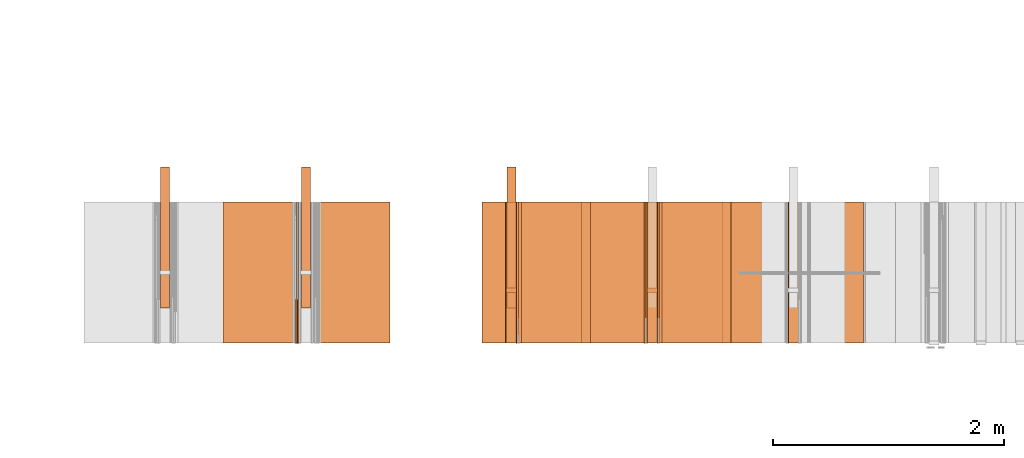
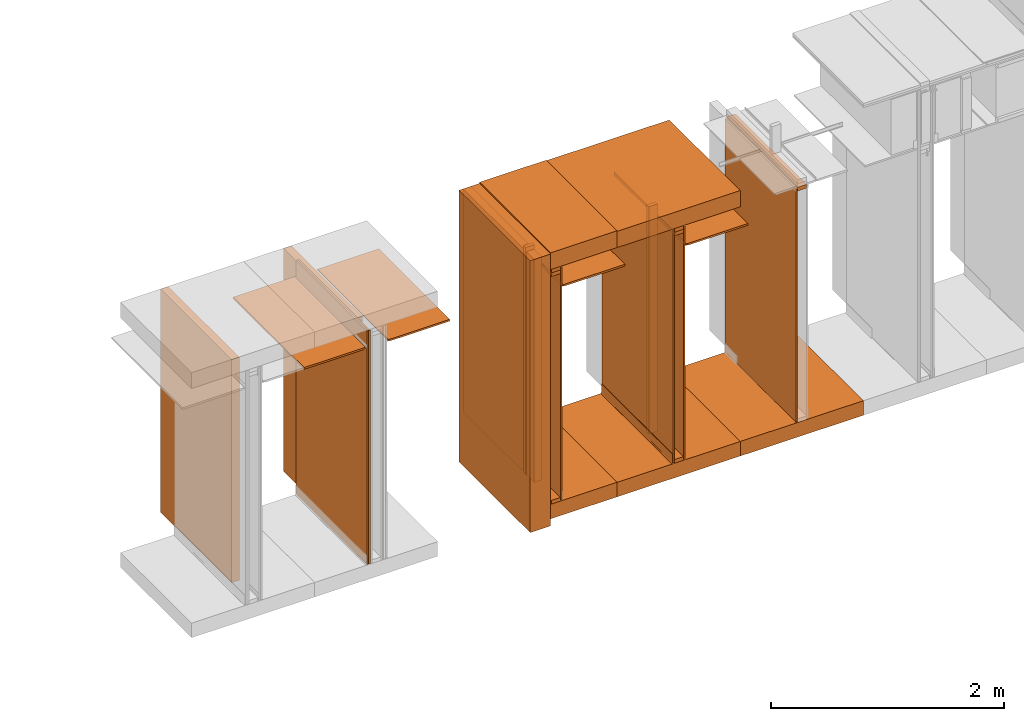
# One storey, part 8 of 38: 31 proxies.
"""IFC4 building model written with IfcOpenShell, lengths in feet."""

from ifc_helpers import new_model, entity, si_unit, converted_unit, frame, origin_with_axes, origin_2d_with_axis, place, context, subcontext, project, spatial, polyline, line, indexed_curve, outline, extrude, material, constituent, constituent_set, element, save


model = new_model("IFC4")

# Units and contexts
model_context_1 = context("Model", 3, precision=1e-05, world=origin_with_axes())
plan_context = context("Plan", 2, precision=1e-05, world=origin_2d_with_axis())
model_context_2 = context("Model", 3, precision=1e-05, world=origin_with_axes())
context_of_model_1 = context(None, 3, precision=1e-05, world=origin_with_axes())
context_of_model_2 = context(None, 3, precision=1e-05, world=origin_with_axes())
body_context = subcontext(model_context_2, "Body", "Model", "MODEL_VIEW")
ifc_project = project(units=[converted_unit("PLANEANGLEUNIT", "degree", entity("IfcReal", 0.0174532925199433), si_unit("PLANEANGLEUNIT", "RADIAN"), dimensions=[0, 0, 0, 0, 0, 0, 0]), converted_unit("AREAUNIT", "square foot", entity("IfcReal", 0.09290304), si_unit("AREAUNIT", "SQUARE_METRE"), dimensions=[2, 0, 0, 0, 0, 0, 0]), converted_unit("LENGTHUNIT", "foot", entity("IfcReal", 0.3048), si_unit("LENGTHUNIT", "METRE"), dimensions=[1, 0, 0, 0, 0, 0, 0]), converted_unit("VOLUMEUNIT", "cubic foot", entity("IfcReal", 0.0283168467116885), si_unit("VOLUMEUNIT", "CUBIC_METRE"), dimensions=[3, 0, 0, 0, 0, 0, 0])], contexts=[model_context_1, plan_context, context_of_model_1, context_of_model_2])

# Site, building, storey
site_placement = place(None, origin_with_axes())
site = spatial("IfcSite", under=ifc_project, at=site_placement)
building_placement = place(site_placement, origin_with_axes())
building = spatial("IfcBuilding", under=site, at=building_placement, Name="Building")
storey_placement = place(building_placement, origin_with_axes())
storey = spatial("IfcBuildingStorey", under=building, at=storey_placement, Name="Storey")

# Proxies
proxy_1_placement = place(storey_placement, frame((1379.04530122211, 5.99999987860051, 7.9530516634463), z_axis=(4.37113882867379e-08, -0.999999999999999, -8.51092183247426e-15), x_axis=(1.94707183709394e-07, 0.0, 0.999999999999981)))
element("IfcBuildingElementProxy", 1, at=proxy_1_placement, inside=storey, Name="Generic Models 48:Generic Models 1", PredefinedType="COMPLEX", context=body_context, shape_type="SweptSolid", body=[
    extrude(outline(polyline([(-0.145833333098669, -0.0625000007724355), (0.145833333098669, -0.0625000007724355), (0.145833333098669, 0.0625000007724355), (-0.145833333098669, 0.062500006883476), (-0.145833333098669, -0.0625000007724355)])), frame((0.0625000313276381, -0.145833320876588, -1.73846880315148e-08), z_axis=(-3.2778077805164e-14, 1.19209289550781e-07, -1.0), x_axis=(-1.94707197920252e-07, 1.0, 1.19209289550781e-07)), (5.72196491577248e-11, 5.40068767485025e-10, -1.0), 4.00000000752362),
])
proxy_2_placement = place(storey_placement, frame((1361.22916314233, 2.99999993930026, 0.125000001544871), z_axis=(0.0, 0.0, 1.0), x_axis=(-1.62920684942944e-07, 0.999999999999987, 0.0)))
element("IfcBuildingElementProxy", 2, at=proxy_2_placement, inside=storey, Name="Generic Models 498:Generic Models 1", PredefinedType="COMPLEX", context=body_context, shape_type="SweptSolid", body=[
    extrude(outline(polyline([(-2.00000002471794, -0.125000001544871), (2.00000002471794, -0.125000001544871), (2.00000002471794, 0.125000001544871), (-2.00000002471794, 0.125000001544871), (-2.00000002471794, -0.125000001544871)])), frame((2.00000002471794, -0.125000001544871, 0.0), z_axis=(0.0, 0.0, -1.0), x_axis=(-1.0, 0.0, 0.0)), (0.0, 0.0, -0.999999940395355), 7.66478654778766),
])
ifc_material_1 = material(Category="sand")
proxy_3_placement = place(storey_placement, frame((1378.99323711245, 5.99999987860051, 0.0208333330815585), z_axis=(4.37113882867379e-08, -0.999999999999999, -8.51092183247426e-15), x_axis=(1.94707183709394e-07, 0.0, 0.999999999999981)))
element("IfcBuildingElementProxy", 3, at=proxy_3_placement, inside=storey, material=ifc_material_1, Name="Generic Models 550:Generic Models 1", PredefinedType="COMPLEX", context=body_context, shape_type="SweptSolid", body=[
    extrude(outline(polyline([(-4.00429713757332, -0.0260416674977682), (4.00429713757332, -0.0260416674977682), (4.00429713757332, 0.0260416674977682), (-4.00429713757332, 0.0260416674977682), (-4.00429713757332, -0.0260416674977682)])), frame((4.00429713757332, -0.0260408883401024, -3.10444292028814e-09), z_axis=(-3.17388734109685e-14, 1.19209289550781e-07, -1.0), x_axis=(1.0, 1.94707183709397e-07, -8.51092267950722e-15)), (-1.26761878771475e-09, 8.29316199046914e-11, -1.0), 4.00000000752362),
])
ifc_material_2 = material(Name="STRUCTURAL FLOOR", Category="concrete")
proxy_4_placement = place(storey_placement, frame((1377.1823072058, 5.99999987860051, -0.500000006179484), z_axis=(4.37113882867379e-08, -0.999999999999999, -8.51092183247426e-15), x_axis=(1.94707183709394e-07, 0.0, 0.999999999999981)))
element("IfcBuildingElementProxy", 4, at=proxy_4_placement, inside=storey, material=ifc_material_2, Name="Generic Models 561:Generic Models 1", PredefinedType="COMPLEX", context=body_context, shape_type="SweptSolid", body=[
    extrude(outline(polyline([(-0.250000003089742, -2.00000002471794), (0.250000003089742, -2.00000002471794), (0.250000003089742, 2.00000002471794), (-0.250000003089742, 2.00000002471794), (-0.250000003089742, -2.00000002471794)])), frame((0.250000394196335, -2.00000002471794, -6.29525198374314e-07), z_axis=(0.0, 1.19209289550781e-07, -1.0), x_axis=(1.0, 1.94707183709397e-07, 0.0)), (4.23038687413779e-10, -9.26340160134487e-09, -1.0), 4.00000000752362),
])
ifc_constituent_set_1 = constituent_set(Name="concrete")
proxy_5_placement = place(storey_placement, frame((1373.18228173444, 5.99999987860051, -0.500000006179484), z_axis=(7.54979012640431e-08, -0.999999999999997, 5.69993288272772e-15), x_axis=(7.54979012640431e-08, 0.0, -0.999999999999997)))
element("IfcBuildingElementProxy", 5, at=proxy_5_placement, inside=storey, material=ifc_constituent_set_1, Name="Generic Models 11:Generic Models 1", PredefinedType="COMPLEX", context=body_context, shape_type="SweptSolid", body=[
    extrude(outline(polyline([(-0.249999905313094, -2.00000002471794), (0.250000174198876, -2.00000002471794), (0.249999880868932, 2.00000002471794), (-0.250000198643039, 2.00000002471794), (-0.249999905313094, -2.00000002471794)])), frame((-0.249999831980608, 2.00000002471794, -5.65952137880985e-07), z_axis=(0.0, -8.74227978897579e-08, -1.0), x_axis=(-1.0, 0.0, 0.0)), (0.0, 1.03538582152396e-08, -1.0), 4.00000000752362),
])
ifc_material_3 = material(Name="CEILING TRACK AS SCHEDULED", Category="poche")
proxy_6_placement = place(storey_placement, frame((1375.38539455944, 5.99999987860051, 7.35498241239332), z_axis=(7.54979012640431e-08, -0.999999999999997, 5.69993288272772e-15), x_axis=(7.54979012640431e-08, 0.0, -0.999999999999997)))
element("IfcBuildingElementProxy", 6, at=proxy_6_placement, inside=storey, material=ifc_material_3, Name="Generic Models 14:Generic Models 1", PredefinedType="COMPLEX", context=body_context, shape_type="SweptSolid", body=[
    extrude(outline(polyline([(-0.043402779162947, -0.029513890441908), (0.0815972223819241, -0.029513890441908), (0.0815972284929646, -0.0243055575534584), (-0.0381944432189771, -0.0243055575534584), (-0.0381944462744974, 0.0538194388288056), (-0.043402779162947, 0.0538194510508866), (-0.043402779162947, -0.029513890441908)])), frame((-0.0434019908387204, 0.0295138812753472, -3.93686786291257e-07), z_axis=(4.20818639808827e-14, -8.74224923563816e-08, -1.0), x_axis=(-1.0, 7.65208625352898e-08, 0.0)), (-1.99266270151099e-10, 2.64895128054832e-09, -1.0), 4.00000000752362),
])
proxy_7_placement = place(storey_placement, frame((1375.04167131239, 5.99999987860051, 7.81249968711472), z_axis=(7.54979012640431e-08, -0.999999999999997, 5.69993288272772e-15), x_axis=(7.54979012640431e-08, 0.0, -0.999999999999997)))
element("IfcBuildingElementProxy", 7, at=proxy_7_placement, inside=storey, Name="Generic Models 155:Generic Models 1", PredefinedType="COMPLEX", context=body_context, shape_type="SweptSolid", body=[
    extrude(outline(polyline([(-0.062500006883476, -0.145833333098669), (0.0625000007724355, -0.145833333098669), (0.062500006883476, 0.145833308654507), (-0.0625000007724355, 0.14583334532075), (-0.062500006883476, -0.145833333098669)])), frame((-0.0624991085605202, 0.145833320876588, -4.03855753155507e-07), z_axis=(0.0, -8.74228121006126e-08, -1.0), x_axis=(-1.0, 9.77766632104249e-08, 0.0)), (5.0926202144197e-10, -3.39597883147746e-09, -1.0), 4.00000000752362),
])
ifc_material_4 = material()
ifc_constituent = constituent(ifc_material_4)
ifc_constituent_set_2 = constituent_set(constituents=[ifc_constituent], Name="wood")
proxy_8_placement = place(storey_placement, frame((1375.04167131239, 5.99999987860051, -4.92006757396041e-14), z_axis=(7.54979012640431e-08, -0.999999999999997, 5.69993288272772e-15), x_axis=(7.54979012640431e-08, 0.0, -0.999999999999997)))
element("IfcBuildingElementProxy", 8, at=proxy_8_placement, inside=storey, material=ifc_constituent_set_2, Name="Generic Models 1:Generic Models 1", PredefinedType="COMPLEX", context=body_context, shape_type="SweptSolid", body=[
    extrude(outline(polyline([(-0.0624999641061924, -0.145833320876588), (0.0625000374386786, -0.145833320876588), (0.0624999579951519, 0.145833357542831), (-0.0625000435497191, 0.145833320876588), (-0.0624999641061924, -0.145833320876588)])), frame((-0.0624999885503545, 0.145833333098669, -4.03855753155507e-07), z_axis=(8.19452029832395e-15, -8.742281920604e-08, -1.0), x_axis=(1.0, 1.9555329799914e-07, 0.0)), (-5.09236153245496e-10, -1.18727372377947e-09, -1.0), 4.00000000752362),
])
proxy_9_placement = place(storey_placement, frame((1370.35419934691, 5.99999987860051, -0.741135700559366), z_axis=(7.54979012640431e-08, -0.999999999999997, 5.69993288272772e-15), x_axis=(7.54979012640431e-08, 0.0, -0.999999999999997)))
element("IfcBuildingElementProxy", 9, at=proxy_9_placement, inside=storey, Name="Generic Models 26:Generic Models 1", PredefinedType="COMPLEX", context=body_context, shape_type="SweptSolid", body=[
    extrude(outline(polyline([(-0.333333329304935, -4.66965471352805), (0.33333337819326, -4.66965471352805), (0.333333304860773, 4.66965471352805), (-0.333333329304935, 4.66965471352805), (-0.333333329304935, -4.66965471352805)])), frame((-4.66965471352805, 0.333333695967366, -4.20247517158809e-07), z_axis=(-1.15161688948276e-15, -8.74227765734759e-08, -1.0), x_axis=(-6.80508804862257e-08, -1.0, 8.74227623626211e-08)), (1.8681878266591e-09, 5.67091396064257e-09, -1.0), 4.00000000752362),
])
proxy_10_placement = place(storey_placement, frame((1375.33333044978, 5.99999987860051, 0.0208333330815585), z_axis=(7.54979012640431e-08, -0.999999999999997, 5.69993288272772e-15), x_axis=(7.54979012640431e-08, 0.0, -0.999999999999997)))
element("IfcBuildingElementProxy", 10, at=proxy_10_placement, inside=storey, material=ifc_material_1, Name="Generic Models 2:Generic Models 1", PredefinedType="COMPLEX", context=body_context, shape_type="SweptSolid", body=[
    extrude(outline(polyline([(-4.01041717354081, -0.0260416644422479), (4.01041717354081, -0.0260416644422479), (4.01041717354081, 0.0260416705532884), (-4.01041717354081, 0.0260416705532884), (-4.01041717354081, -0.0260416644422479)])), frame((-4.01041717354081, 0.026041973049794, -3.9338322042823e-07), z_axis=(-7.82204010086772e-16, -8.74215970725345e-08, -1.0), x_axis=(1.0, -7.54276925363229e-08, 5.8128042581141e-15)), (-4.91072238428814e-10, 3.39262007376107e-10, -1.0), 4.00000000752362),
])
proxy_11_placement = place(storey_placement, frame((1371.04164584102, 5.99999987860051, -4.92006757396041e-14), z_axis=(7.54979012640431e-08, -0.999999999999997, 5.69993288272772e-15), x_axis=(7.54979012640431e-08, 0.0, -0.999999999999997)))
element("IfcBuildingElementProxy", 11, at=proxy_11_placement, inside=storey, Name="Generic Models 36:Generic Models 1", PredefinedType="COMPLEX", context=body_context, shape_type="SweptSolid", body=[
    extrude(outline(polyline([(-0.0624999641061924, -0.145833320876588), (0.0625000374386786, -0.145833320876588), (0.0624999579951519, 0.145833357542831), (-0.0625000435497191, 0.145833320876588), (-0.0624999641061924, -0.145833320876588)])), frame((-0.0624999885503545, 0.145833333098669, -4.03855753155507e-07), z_axis=(8.19452029832395e-15, -8.742281920604e-08, -1.0), x_axis=(1.0, 1.9555329799914e-07, 0.0)), (-5.09236153245496e-10, -1.18727372377947e-09, -1.0), 4.00000000752362),
])
proxy_12_placement = place(storey_placement, frame((1371.38536908808, 5.99999987860051, 7.35498241239332), z_axis=(7.54979012640431e-08, -0.999999999999997, 5.69993288272772e-15), x_axis=(7.54979012640431e-08, 0.0, -0.999999999999997)))
element("IfcBuildingElementProxy", 12, at=proxy_12_placement, inside=storey, material=ifc_material_3, Name="Generic Models 454:Generic Models 1", PredefinedType="COMPLEX", context=body_context, shape_type="SweptSolid", body=[
    extrude(outline(polyline([(-0.0434027761074267, -0.029513890441908), (0.081597210159843, -0.029513890441908), (0.0815972162708836, -0.0243055575534584), (-0.0381944432189771, -0.0243055575534584), (-0.0381944432189771, 0.0538194388288056), (-0.0434027761074267, 0.0538194449398461), (-0.0434027761074267, -0.029513890441908)])), frame((-0.0434039097054424, 0.0295138812753472, -2.5801856277088e-09), z_axis=(4.20819995061543e-14, -8.74227765734759e-08, -1.0), x_axis=(-1.0, 7.65208696407171e-08, -6.68966674115539e-15)), (-1.99272875978096e-10, 2.64862309862224e-09, -1.0), 4.00000000752362),
])
ifc_material_5 = material(Name="UNDERSIDE OF FLOOR ASSEMBLY", Category="sand")
proxy_13_placement = place(storey_placement, frame((1373.18228173444, 5.99999987860051, 8.06249971464863), z_axis=(7.54979012640431e-08, -0.999999999999997, 5.69993288272772e-15), x_axis=(7.54979012640431e-08, 0.0, -0.999999999999997)))
element("IfcBuildingElementProxy", 13, at=proxy_13_placement, inside=storey, material=ifc_material_5, Name="Generic Models 499:Generic Models 1", PredefinedType="COMPLEX", context=body_context, shape_type="SweptSolid", body=[
    extrude(outline(polyline([(-0.279213050062575, -2.00000002471794), (0.279213318948358, -2.00000002471794), (0.279213025618413, 2.00000002471794), (-0.279213392280844, 2.00000002471794), (-0.279213050062575, -2.00000002471794)])), frame((-0.279211583412851, 2.00000002471794, -5.65952137880985e-07), z_axis=(0.0, -8.74227765734759e-08, -1.0), x_axis=(1.0, 0.0, 0.0)), (0.0, -1.03538813078785e-08, -1.0), 4.00000000752362),
])
proxy_14_placement = place(storey_placement, frame((1371.02082019716, 5.99999987860051, -0.500000006179484), z_axis=(7.54979012640431e-08, -0.999999999999997, 5.69993288272772e-15), x_axis=(7.54979012640431e-08, 0.0, -0.999999999999997)))
element("IfcBuildingElementProxy", 14, at=proxy_14_placement, inside=storey, material=ifc_material_2, Name="Generic Models 500:Generic Models 1", PredefinedType="COMPLEX", context=body_context, shape_type="SweptSolid", body=[
    extrude(outline(polyline([(-0.249999905313094, -1.0807292042129), (0.250000076422228, -1.0807292042129), (0.249999905313094, 1.0807292042129), (-0.250000051978066, 1.0807292042129), (-0.249999905313094, -1.0807292042129)])), frame((-0.249999954201418, 1.0807292042129, -4.85586957054172e-07), z_axis=(0.0, -8.74227907843306e-08, -1.0), x_axis=(1.0, 0.0, 0.0)), (0.0, -1.03538644324885e-08, -1.0), 4.00000000752362),
])
ifc_material_6 = material(Name="DOUBLE 2X WOOD TOP PLATE")
proxy_15_placement = place(storey_placement, frame((1375.04167131239, 5.99999987860051, 7.93749970088168), z_axis=(7.54979012640431e-08, -0.999999999999997, 5.69993288272772e-15), x_axis=(7.54979012640431e-08, 0.0, -0.999999999999997)))
element("IfcBuildingElementProxy", 15, at=proxy_15_placement, inside=storey, material=ifc_material_6, Name="Generic Models 6:Generic Models 1", PredefinedType="COMPLEX", context=body_context, shape_type="SweptSolid", body=[
    extrude(outline(polyline([(-0.062500006883476, -0.145833333098669), (0.0625000007724355, -0.145833333098669), (0.062500006883476, 0.145833308654507), (-0.0625000007724355, 0.14583334532075), (-0.062500006883476, -0.145833333098669)])), frame((-0.0624991085605202, 0.145833320876588, -4.03855753155507e-07), z_axis=(0.0, -8.74228121006126e-08, -1.0), x_axis=(-1.0, 9.77766632104249e-08, 0.0)), (5.0926202144197e-10, -3.39597883147746e-09, -1.0), 4.00000000752362),
])
ifc_constituent_set_3 = constituent_set(Name="poche")
proxy_16_placement = place(storey_placement, frame((1374.95506466843, 5.99999987860051, -4.92006757396041e-14), z_axis=(7.54979012640431e-08, -0.999999999999997, 5.69993288272772e-15), x_axis=(7.54979012640431e-08, 0.0, -0.999999999999997)))
element("IfcBuildingElementProxy", 16, at=proxy_16_placement, inside=storey, material=ifc_constituent_set_3, Name="Generic Models 42:Generic Models 1", PredefinedType="COMPLEX", context=body_context, shape_type="SweptSolid", body=[
    extrude(outline(polyline([(0.0865199099590616, -8.5939931170287e-10), (0.0746953398908373, -0.00423440261159747), (0.0621777228287512, -0.00526409536927665), (-0.213292693802378, 0.00819644836948456), (-0.218226039034175, 0.00642983669420005), (-0.220465222055831, 0.00169228920053075), (-0.220639508931343, -0.00187364654991962), (0.0616693270351161, -0.0156683412202074), (0.0768970805672523, -0.0144157215239104), (0.0912817488387814, -0.00926454596128559), (0.103843065951596, -0.000565859912790778), (0.113724972906075, 0.0110875258742883), (0.104968829613345, 0.0167299343732594), (0.0968456251199633, 0.00715054454907697), (0.0865199099590616, -8.5939931170287e-10)])), frame((-0.113048162946864, 0.0218330794490698, -3.93015360704795e-07), z_axis=(-2.55675960004337e-13, -8.74225420943731e-08, -1.0), x_axis=(0.998808324337006, -0.0488056913018227, 4.26736290748408e-09)), (-2.34471624338539e-08, 2.81413847780243e-09, -1.0), 4.00000000752362),
])
ifc_constituent_set_4 = constituent_set(Name="sand")
proxy_17_placement = place(storey_placement, frame((1374.98960720272, 5.99999987860051, 0.0208333330815585), z_axis=(7.54979012640431e-08, -0.999999999999997, 5.69993288272772e-15), x_axis=(7.54979012640431e-08, 0.0, -0.999999999999997)))
element("IfcBuildingElementProxy", 17, at=proxy_17_placement, inside=storey, material=ifc_constituent_set_4, Name="Generic Models 9:Generic Models 1", PredefinedType="COMPLEX", context=body_context, shape_type="SweptSolid", body=[
    extrude(outline(polyline([(-0.0260413650012626, -4.01041717354081), (0.0260419699942737, -4.01041717354081), (0.0260413650012626, 4.01041717354081), (-0.0260419699942737, 4.01041717354081), (-0.0260413650012626, -4.01041717354081)])), frame((-4.01041717354081, 0.0260419699942737, -3.9338322042823e-07), z_axis=(6.70460564948787e-16, -8.74218102353552e-08, -1.0), x_axis=(0.0, -1.0, 8.74220376090307e-08)), (3.39704930851781e-10, -7.28492803868429e-16, -1.0), 4.00000000752362),
])
proxy_18_placement = place(storey_placement, frame((1371.42962358129, 5.99999987860051, 7.33943123204189), z_axis=(7.54979012640431e-08, -0.999999999999997, 5.69993288272772e-15), x_axis=(7.54979012640431e-08, 0.0, -0.999999999999997)))
element("IfcBuildingElementProxy", 18, at=proxy_18_placement, inside=storey, Name="Generic Models 503:Generic Models 1", PredefinedType="COMPLEX", context=body_context, shape_type="SweptSolid", body=[
    extrude(outline(polyline([(0.640468627918424, -0.00347222294413981), (0.682135315470182, -0.00347222294413981), (0.682135315470182, 0.0329861103305275), (-1.31786466035943, 0.032986104219487), (-1.31786466035943, -0.029513890441908), (0.630990257413368, -0.0295138873863877), (0.640468627918424, -0.00347222294413981)])), frame((-0.0295149904292008, 0.682135315470182, -5.96341698681725e-08), z_axis=(0.0, -8.74227836789032e-08, -1.0), x_axis=(-7.33324512225408e-08, -1.0, 8.74227907843306e-08)), (-9.81275682931937e-09, 2.83582712867769e-10, -1.0), 4.00000000752362),
])
proxy_19_placement = place(storey_placement, frame((1371.04164584102, 3.44270835398376, 0.125000001544871), z_axis=(0.999999999999981, 0.0, 1.94707183709394e-07), x_axis=(1.94707183709394e-07, 0.0, -0.999999999999981)))
element("IfcBuildingElementProxy", 19, at=proxy_19_placement, inside=storey, Name="Generic Models 504:Generic Models 65", PredefinedType="COMPLEX", context=body_context, shape_type="SweptSolid", body=[
    extrude(outline(polyline([(-3.90624984355736, -0.0625000007724355), (3.90624984355736, -0.0625000007724355), (3.90624984355736, 0.0625000007724355), (-3.90624984355736, 0.0625000007724355), (-3.90624984355736, -0.0625000007724355)])), frame((-3.90624984355736, 0.0625000007724355, 2.94913769695501e-07), z_axis=(-7.54979012640433e-08, 0.0, -1.0), x_axis=(1.0, 0.0, -7.54979083694707e-08)), (-7.54979865291716e-08, 0.0, -1.0), 0.291666664589755),
])
proxy_20_placement = place(storey_placement, frame((1371.04164584102, 5.99999987860051, 7.81249968711472), z_axis=(7.54979012640431e-08, -0.999999999999997, 5.69993288272772e-15), x_axis=(7.54979012640431e-08, 0.0, -0.999999999999997)))
element("IfcBuildingElementProxy", 20, at=proxy_20_placement, inside=storey, Name="Generic Models 505:Generic Models 1", PredefinedType="COMPLEX", context=body_context, shape_type="SweptSolid", body=[
    extrude(outline(polyline([(-0.0624999579951519, -0.145833320876588), (0.0625000374386786, -0.145833320876588), (0.0624999579951519, 0.145833357542831), (-0.0625000374386786, 0.145833320876588), (-0.0624999579951519, -0.145833320876588)])), frame((-0.0625010213162017, 0.145833333098669, -4.03855753155507e-07), z_axis=(8.1945211453569e-15, -8.742281920604e-08, -1.0), x_axis=(1.0, 1.95553312209995e-07, 0.0)), (-5.0923543160053e-10, -1.187324571994e-09, -1.0), 4.00000000752362),
])
proxy_21_placement = place(storey_placement, frame((1371.06247148489, 2.99999993930026, 0.125000001544871), z_axis=(-1.62920684942944e-07, 0.999999999999987, -1.23001694617954e-14), x_axis=(7.54979012640431e-08, 0.0, -0.999999999999997)))
element("IfcBuildingElementProxy", 21, at=proxy_21_placement, inside=storey, Name="Generic Models 506:Generic Models 1", PredefinedType="COMPLEX", context=body_context, shape_type="SweptSolid", body=[
    extrude(outline(polyline([(-3.83239327453253, -0.125000001544871), (3.83239327453253, -0.125000001544871), (3.83239327453253, 0.125000013766952), (-3.83239327453253, 0.125000001544871), (-3.83239327453253, -0.125000001544871)])), frame((-3.83239327453253, -0.125000294874816, -4.20396346619738e-14), z_axis=(1.23001711558614e-14, 0.0, -1.0), x_axis=(-0.999999940395355, -7.65396208635138e-08, -1.23001694617955e-14)), (2.39185649064666e-09, 1.16558848618949e-14, -1.0), 4.00000000752362),
])
proxy_22_placement = place(storey_placement, frame((1371.04164584102, 5.99999987860051, 7.93749970088168), z_axis=(7.54979012640431e-08, -0.999999999999997, 5.69993288272772e-15), x_axis=(7.54979012640431e-08, 0.0, -0.999999999999997)))
element("IfcBuildingElementProxy", 22, at=proxy_22_placement, inside=storey, Name="Generic Models 508:Generic Models 1", PredefinedType="COMPLEX", context=body_context, shape_type="SweptSolid", body=[
    extrude(outline(polyline([(-0.0624999579951519, -0.145833320876588), (0.0625000374386786, -0.145833320876588), (0.0624999579951519, 0.145833357542831), (-0.0625000374386786, 0.145833320876588), (-0.0624999579951519, -0.145833320876588)])), frame((-0.0625010213162017, 0.145833333098669, -4.03855753155507e-07), z_axis=(8.1945211453569e-15, -8.742281920604e-08, -1.0), x_axis=(1.0, 1.95553312209995e-07, 0.0)), (-5.0923543160053e-10, -1.187324571994e-09, -1.0), 4.00000000752362),
])
proxy_23_placement = place(storey_placement, frame((1375.04167131239, 3.44270835398376, 0.125000001544871), z_axis=(0.999999999999981, 0.0, 1.94707183709394e-07), x_axis=(1.94707183709394e-07, 0.0, -0.999999999999981)))
element("IfcBuildingElementProxy", 23, at=proxy_23_placement, inside=storey, Name="Generic Models 52:Generic Models 65", PredefinedType="COMPLEX", context=body_context, shape_type="SweptSolid", body=[
    extrude(outline(polyline([(-3.90624984355736, -0.0625000007724355), (3.90624984355736, -0.0625000007724355), (3.90624984355736, 0.0625000007724355), (-3.90624984355736, 0.0625000007724355), (-3.90624984355736, -0.0625000007724355)])), frame((-3.90624984355736, 0.0625000007724355, 2.94913769695501e-07), z_axis=(-7.54979012640433e-08, 0.0, -1.0), x_axis=(-1.0, 0.0, 7.54979083694707e-08)), (7.54979865291716e-08, 0.0, -1.0), 0.291666664589755),
])
proxy_24_placement = place(storey_placement, frame((1371.33330497842, 5.99999987860051, 0.0208333330815585), z_axis=(7.54979012640431e-08, -0.999999999999997, 5.69993288272772e-15), x_axis=(7.54979012640431e-08, 0.0, -0.999999999999997)))
element("IfcBuildingElementProxy", 24, at=proxy_24_placement, inside=storey, material=ifc_material_1, Name="Generic Models 67:Generic Models 1", PredefinedType="COMPLEX", context=body_context, shape_type="SweptSolid", body=[
    extrude(outline(polyline([(-0.0260413650012626, -4.01041717354081), (0.0260419699942737, -4.01041717354081), (0.0260413650012626, 4.01041717354081), (-0.0260419699942737, 4.01041717354081), (-0.0260413650012626, -4.01041717354081)])), frame((-4.01041717354081, 0.0260419699942737, -3.9338322042823e-07), z_axis=(-7.82204010086772e-16, -8.74215970725345e-08, -1.0), x_axis=(0.0, 1.0, -8.74215899671071e-08)), (-3.39256178705227e-10, -7.28492803868429e-16, -1.0), 4.00000000752362),
])
proxy_25_placement = place(storey_placement, frame((1371.02082019716, 5.99999987860051, 8.06249971464863), z_axis=(7.54979012640431e-08, -0.999999999999997, 5.69993288272772e-15), x_axis=(7.54979012640431e-08, 0.0, -0.999999999999997)))
element("IfcBuildingElementProxy", 25, at=proxy_25_placement, inside=storey, material=ifc_material_5, Name="Generic Models 7:Generic Models 1", PredefinedType="COMPLEX", context=body_context, shape_type="SweptSolid", body=[
    extrude(outline(polyline([(-0.288976855048044, -1.0807292042129), (0.288976855048044, -1.0807292042129), (0.288976855048044, 1.0807292042129), (-0.288976879492207, 1.0807292042129), (-0.288976855048044, -1.0807292042129)])), frame((-0.288977808370365, 1.0807292042129, -4.85586957054172e-07), z_axis=(0.0, -8.74227978897579e-08, -1.0), x_axis=(-1.0, 6.78546427934634e-08, 0.0)), (8.74191364642115e-15, 5.45173683974554e-09, -1.0), 4.00000000752362),
])
proxy_26_placement = place(storey_placement, frame((1375.42964905266, 5.99999987860051, 7.33943123204189), z_axis=(7.54979012640431e-08, -0.999999999999997, 5.69993288272772e-15), x_axis=(7.54979012640431e-08, 0.0, -0.999999999999997)))
element("IfcBuildingElementProxy", 26, at=proxy_26_placement, inside=storey, Name="Generic Models 49:Generic Models 1", PredefinedType="COMPLEX", context=body_context, shape_type="SweptSolid", body=[
    extrude(outline(polyline([(0.640468627918424, -0.00347222599966007), (0.682135315470182, -0.00347222599966007), (0.682135315470182, 0.0329861194970883), (-1.31786466035943, 0.0329861133860478), (-1.31786475813608, -0.0295138965529485), (0.630990257413368, -0.0295138934974282), (0.640468627918424, -0.00347222599966007)])), frame((-0.0295130746179991, 0.682135315470182, -4.50740757054604e-07), z_axis=(0.0, -8.74227836789032e-08, -1.0), x_axis=(-7.33324512225408e-08, -1.0, 8.74224497238174e-08)), (-9.81314229875352e-09, 2.83582712867769e-10, -1.0), 4.00000000752362),
])
proxy_27_placement = place(storey_placement, frame((1365.74212021715, 5.99999987860051, 7.43870660075991), z_axis=(4.37113882867379e-08, -0.999999999999999, -8.51092183247426e-15), x_axis=(1.94707183709394e-07, 0.0, 0.999999999999981)))
element("IfcBuildingElementProxy", 27, at=proxy_27_placement, inside=storey, Name="Generic Models 27:Generic Models 1", PredefinedType="COMPLEX", context=body_context, shape_type="SweptSolid", body=[
    extrude(outline(polyline([(-0.0329863700497495, -1.31786475813608), (0.0295136337782063, -1.31786475813608), (0.0295140126627183, 0.630990257413368), (0.00347234516495013, 0.640468627918424), (0.0034723543315109, 0.682135315470182), (-0.0329859789431564, 0.682135315470182), (-0.0329863700497495, -1.31786475813608)])), frame((0.0295140218292791, -0.682135315470182, -4.7242345352113e-07), z_axis=(5.53375813054646e-13, 1.19209303761636e-07, -1.0), x_axis=(-1.0, 0.0, 0.0)), (0.0, -3.01151925619081e-09, -1.0), 4.00000000752362),
])
proxy_28_placement = place(storey_placement, frame((1365.22918861369, 2.99999993930026, 0.125000001544871), z_axis=(0.0, 0.0, 1.0), x_axis=(-1.62920684942944e-07, 0.999999999999987, 0.0)))
element("IfcBuildingElementProxy", 28, at=proxy_28_placement, inside=storey, Name="Generic Models 330:Generic Models 1", PredefinedType="COMPLEX", context=body_context, shape_type="SweptSolid", body=[
    extrude(outline(polyline([(-2.00000002471794, -0.125000001544871), (2.00000002471794, -0.125000001544871), (2.00000002471794, 0.125000001544871), (-2.00000002471794, 0.125000001544871), (-2.00000002471794, -0.125000001544871)])), frame((2.00000002471794, -0.125000001544871, 0.0), z_axis=(0.0, 0.0, -1.0), x_axis=(-1.0, 0.0, 0.0)), (0.0, 0.0, -0.999999940395355), 7.66478654778766),
])
proxy_29_placement = place(storey_placement, frame((1365.10413462721, 5.99999987860051, 0.0208333330815585), z_axis=(4.37113882867379e-08, -0.999999999999999, -8.51092183247426e-15), x_axis=(1.94707183709394e-07, 0.0, 0.999999999999981)))
element("IfcBuildingElementProxy", 29, at=proxy_29_placement, inside=storey, Name="Generic Models 340:Generic Models 1", PredefinedType="COMPLEX", context=body_context, shape_type="SweptSolid", body=[
    extrude(outline(polyline([(-0.0260416674977682, -4.01041717354081), (0.0260416674977682, -4.01041717354081), (0.0260416674977682, 4.01041717354081), (-0.0260416644422479, 4.01041717354081), (-0.0260416674977682, -4.01041717354081)])), frame((4.01041717354081, -0.0260408852845821, -3.94210974741267e-07), z_axis=(-2.90532910771947e-14, 1.19209140336807e-07, -1.0), x_axis=(-1.94707169498542e-07, 1.0, 1.19209147442234e-07)), (3.82907483498229e-10, -1.26761567909028e-09, -1.0), 4.00000000752362),
])
proxy_30_placement = place(storey_placement, frame((1363.0078533503, 5.99999987860051, 7.43870660075991), z_axis=(4.37113882867379e-08, -0.999999999999999, -8.51092183247426e-15), x_axis=(1.94707183709394e-07, 0.0, 0.999999999999981)))
element("IfcBuildingElementProxy", 30, at=proxy_30_placement, inside=storey, Name="Generic Models 37:Generic Models 1", PredefinedType="COMPLEX", context=body_context, shape_type="SweptSolid", body=[
    extrude(outline(polyline([(-1.31786475813608, -0.0329861103305275), (0.682135266581858, -0.0329861103305275), (0.682135266581858, 0.00347222599966007), (0.640468530141775, 0.0034722240899599), (0.630990257413368, 0.0295138934974282), (-1.31786475813608, 0.029513890441908), (-1.31786475813608, -0.0329861103305275)])), frame((0.0295141471056097, -1.31786475813608, -5.48208291244019e-07), z_axis=(0.0, 1.19209289550781e-07, -1.0), x_axis=(1.9555329799914e-07, -1.0, -1.19209303761636e-07)), (4.4544163912974e-09, 2.62274896245529e-10, -1.0), 4.00000000752362),
])
proxy_31_placement = place(storey_placement, frame((1365.05207051755, 5.99999987860051, 0.0208333330815585), z_axis=(4.37113882867379e-08, -0.999999999999999, -8.51092183247426e-15), x_axis=(1.94707183709394e-07, 0.0, 0.999999999999981)))
element("IfcBuildingElementProxy", 31, at=proxy_31_placement, inside=storey, material=ifc_material_1, Name="Generic Models 571:Generic Models 1", PredefinedType="COMPLEX", context=body_context, shape_type="SweptSolid", body=[
    extrude(outline(indexed_curve([(-4.01041717354081, -0.0260416674977682), (4.01041717354081, -0.0260416674977682), (4.01041717354081, 0.0260416644422479), (-4.01041717354081, 0.0260416674977682)], segments=[line(4, 1), line(1, 2), line(2, 3), line(3, 4)], self_intersect=False)), frame((4.01041717354081, -0.0260408852845821, -3.94211021364806e-07), z_axis=(-2.90532910771947e-14, 1.19209140336807e-07, -1.0), x_axis=(1.0, 1.94707197920252e-07, -5.8128042581141e-15)), (-1.26761612317949e-09, -3.82860854131195e-10, -1.0), 4.00000000752362),
])

save(model, "model.ifc")
